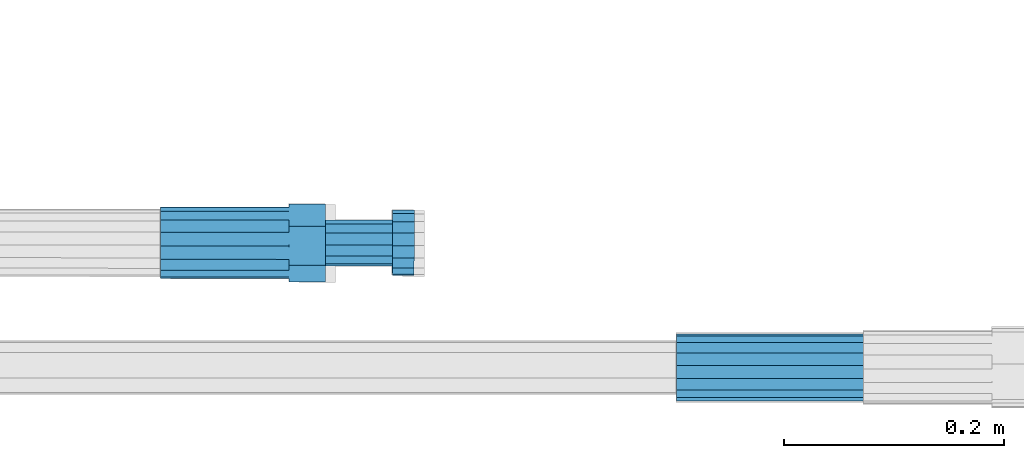
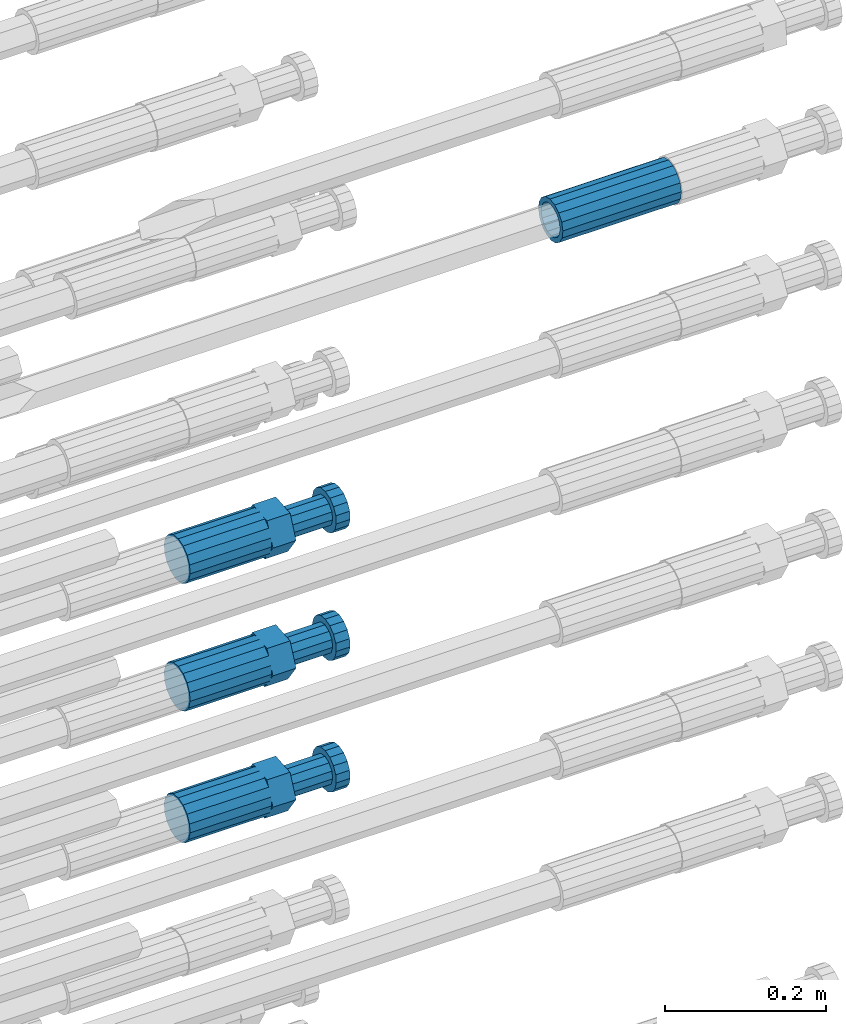
# One storey, part 102 of 177: 4 beams.
"""IFC2X3 building model written with IfcOpenShell, lengths in millimetres."""

import ifcopenshell
import ifcopenshell.guid

model = None  # the IFC model being written
_history = None  # IfcOwnerHistory: only IFC2X3 demands one
_inside = {}  # id of a spatial element -> (the spatial element, [elements in it])
_under = {}  # id of a project, library or spatial element -> (it, [spatial elements below it])
_declared = {}  # id of a project -> (the project, [libraries it declares])
_typed = {}  # id of a type object -> (the type object, [elements of that type])
_made_of = {}  # id of a material, layer set ... -> (it, [elements and type objects made of it])


def new_model(schema):
    """Start an empty IFC model of exactly this schema.

    Asked for "IFC4X3", IfcOpenShell would pick the latest addendum, in which some entities
    have other attributes; the version numbers below select the first issue.
    IFC2X3 requires an IfcOwnerHistory on every rooted entity: one is made here for all.
    """
    global model, _history
    if schema == "IFC4X3":
        model = ifcopenshell.file(schema_version=(4, 3, 0, 0))
    else:
        model = ifcopenshell.file(schema=schema)
    _inside.clear()
    _under.clear()
    _declared.clear()
    _typed.clear()
    _made_of.clear()
    _history = None
    if model.schema == "IFC2X3":
        org = make("IfcOrganization", Name="unknown")
        user = make(
            "IfcPersonAndOrganization",
            ThePerson=make("IfcPerson", FamilyName="unknown"),
            TheOrganization=org,
        )
        app = make(
            "IfcApplication",
            ApplicationDeveloper=org,
            Version="unknown",
            ApplicationFullName="unknown",
            ApplicationIdentifier="unknown",
        )
        _history = make(
            "IfcOwnerHistory",
            OwningUser=user,
            OwningApplication=app,
            ChangeAction="ADDED",
            CreationDate=0,
        )
    return model


def make(cls, **values):
    """One entity of the class cls with the attributes given. An attribute that is None is left unset."""
    return model.create_entity(
        cls, **{name: value for name, value in values.items() if value is not None}
    )


def rooted(cls, **values):
    """An entity with a GlobalId (a new one), such as an element, a storey or a relation."""
    return make(cls, GlobalId=ifcopenshell.guid.new(), OwnerHistory=_history, **values)


def si_unit(unit_type, name, prefix=None):
    """IfcSIUnit, for example si_unit("LENGTHUNIT", "METRE", prefix="MILLI")."""
    return make("IfcSIUnit", UnitType=unit_type, Prefix=prefix, Name=name)


def assignment(units):
    """IfcUnitAssignment: the units of a project."""
    return None if units is None else make("IfcUnitAssignment", Units=units)


def point(xyz):
    """IfcCartesianPoint."""
    return None if xyz is None else make("IfcCartesianPoint", Coordinates=xyz)


def direction(xyz):
    """IfcDirection."""
    return None if xyz is None else make("IfcDirection", DirectionRatios=xyz)


def frame(location, z_axis=None, x_axis=None):
    """IfcAxis2Placement3D, a coordinate frame: its origin and axes. An axis left out is left unset."""
    return make(
        "IfcAxis2Placement3D",
        Location=point(location),
        Axis=direction(z_axis),
        RefDirection=direction(x_axis),
    )


def origin_with_axes():
    """The frame at (0, 0, 0) with the z axis (0, 0, 1) and the x axis (1, 0, 0) written out."""
    return frame((0.0, 0.0, 0.0), z_axis=(0.0, 0.0, 1.0), x_axis=(1.0, 0.0, 0.0))


def place(relative_to, where):
    """IfcLocalPlacement: puts the frame where relative to a parent placement (None: the world)."""
    return make(
        "IfcLocalPlacement", PlacementRelTo=relative_to, RelativePlacement=where
    )


def context(
    kind, dimensions, precision=None, world=None, true_north=None, identifier=None
):
    """IfcGeometricRepresentationContext, for example the 3D "Model" context."""
    return make(
        "IfcGeometricRepresentationContext",
        ContextIdentifier=identifier,
        ContextType=kind,
        CoordinateSpaceDimension=dimensions,
        Precision=precision,
        WorldCoordinateSystem=world,
        TrueNorth=true_north,
    )


def subcontext(parent, identifier, kind, view, scale=None):
    """IfcGeometricRepresentationSubContext, for example "Body" below "Model"."""
    return make(
        "IfcGeometricRepresentationSubContext",
        ContextIdentifier=identifier,
        ContextType=kind,
        ParentContext=parent,
        TargetScale=scale,
        TargetView=view,
    )


def project(units=None, contexts=None):
    """IfcProject with its units and contexts."""
    return rooted(
        "IfcProject",
        Name="project",
        RepresentationContexts=contexts,
        UnitsInContext=assignment(units),
    )


def spatial(cls, under=None, at=None, **own):
    """A site, building, storey or space (cls), placed at a placement, below another one or the project."""
    s = rooted(cls, ObjectPlacement=at, **own)
    if under is not None:
        _under.setdefault(under.id(), (under, []))[1].append(s)
    return s


def faces_of(points, faces, orient=None, outer=None):
    """IfcFace entities. A face is a list of loops; a loop is a list of indices into points, from 0.

    orient and outer hold one flag for each loop. By default every Orientation is true, the
    first loop of a face is its IfcFaceOuterBound and the others are IfcFaceBound.
    """
    made = []
    for i, loops in enumerate(faces):
        bounds = []
        for j, loop in enumerate(loops):
            is_outer = j == 0 if outer is None else outer[i][j]
            bounds.append(
                make(
                    "IfcFaceOuterBound" if is_outer else "IfcFaceBound",
                    Bound=make("IfcPolyLoop", Polygon=[points[k] for k in loop]),
                    Orientation=True if orient is None else orient[i][j],
                )
            )
        made.append(make("IfcFace", Bounds=bounds))
    return made


def faceted_brep(points, faces, orient=None, outer=None, voids=None):
    """IfcFacetedBrep: a solid bounded by flat faces; with voids (closed shells), ...WithVoids."""
    shared = [point(p) for p in points]
    hull = make("IfcClosedShell", CfsFaces=faces_of(shared, faces, orient, outer))
    if voids is None:
        return make("IfcFacetedBrep", Outer=hull)
    return make(
        "IfcFacetedBrepWithVoids",
        Outer=hull,
        Voids=[
            make(cls, CfsFaces=faces_of(shared, fs, o, b)) for cls, fs, o, b in voids
        ],
    )


def shape(context_of_items, identifier, shape_type, items):
    """IfcShapeRepresentation: the items that make up one representation, for example the "Body"."""
    return make(
        "IfcShapeRepresentation",
        ContextOfItems=context_of_items,
        RepresentationIdentifier=identifier,
        RepresentationType=shape_type,
        Items=items,
    )


def material(Name=None, Category=None):
    """IfcMaterial."""
    return make("IfcMaterial", Name=Name, Category=Category)


def made_of(thing, what):
    """Note that an element or type object is made of a material, layer set ...; save() writes the relation."""
    if what is not None:
        _made_of.setdefault(what.id(), (what, []))[1].append(thing)
    return thing


def type_object(cls, material=None, **own):
    """A type object (cls), such as IfcWallType, which elements share."""
    return made_of(rooted(cls, **own), material)


def element(
    cls,
    number,
    at=None,
    inside=None,
    cuts=None,
    type_object=None,
    material=None,
    context=None,
    identifier="Body",
    shape_type=None,
    held_by="IfcProductDefinitionShape",
    body=None,
    shapes=None,
    **own,
):
    """One element of the class cls, such as IfcWall. Its Tag is "e" and its number.

    at: its placement. inside: the storey or other place that contains it. cuts: it is an
    opening in that element (IfcRelVoidsElement). A single representation is given by context,
    identifier, shape_type and body (its items); several are given by shapes. held_by: the class
    of the entity that holds the representations. save() writes the other relations.
    """
    e = rooted(cls, Tag="e%d" % number, ObjectPlacement=at, **own)
    if body is not None:
        shapes = [shape(context, identifier, shape_type, body)]
    if shapes is not None:
        e.Representation = make(held_by, Representations=shapes)
    if inside is not None:
        _inside.setdefault(inside.id(), (inside, []))[1].append(e)
    if cuts is not None:
        rooted(
            "IfcRelVoidsElement", RelatingBuildingElement=cuts, RelatedOpeningElement=e
        )
    if type_object is not None:
        _typed.setdefault(type_object.id(), (type_object, []))[1].append(e)
    return made_of(e, material)


def aggregate(whole, parts):
    """IfcRelAggregates: a whole, such as a stair, and the parts it consists of."""
    return rooted("IfcRelAggregates", RelatingObject=whole, RelatedObjects=parts)


def save(model, path):
    """Write the relations noted so far, then the file.

    IfcRelAggregates (storeys below a building ...), IfcRelContainedInSpatialStructure (elements
    in a storey), IfcRelDefinesByType, IfcRelAssociatesMaterial and IfcRelDeclares: one each for
    every whole, place, type object, material and project.
    """
    for whole, parts in _under.values():
        aggregate(whole, parts)
    for where, things in _inside.values():
        rooted(
            "IfcRelContainedInSpatialStructure",
            RelatedElements=things,
            RelatingStructure=where,
        )
    for kind, things in _typed.values():
        rooted("IfcRelDefinesByType", RelatedObjects=things, RelatingType=kind)
    for what, things in _made_of.values():
        rooted("IfcRelAssociatesMaterial", RelatedObjects=things, RelatingMaterial=what)
    for by, libraries in _declared.values():
        rooted("IfcRelDeclares", RelatingContext=by, RelatedDefinitions=libraries)
    model.write(path)


model = new_model("IFC2X3")

# Units and contexts
model_context_1 = context("Model", 3, precision=1e-05, world=origin_with_axes())
model_context_2 = context("Model", 3, precision=1e-05, world=origin_with_axes())
body_context = subcontext(model_context_2, "Body", "Model", "MODEL_VIEW")
ifc_project = project(units=[si_unit("LENGTHUNIT", "METRE", prefix="MILLI"), si_unit("AREAUNIT", "SQUARE_METRE"), si_unit("VOLUMEUNIT", "CUBIC_METRE"), si_unit("MASSUNIT", "GRAM", prefix="KILO"), si_unit("TIMEUNIT", "SECOND"), si_unit("PLANEANGLEUNIT", "RADIAN"), si_unit("SOLIDANGLEUNIT", "STERADIAN"), si_unit("THERMODYNAMICTEMPERATUREUNIT", "DEGREE_CELSIUS"), si_unit("LUMINOUSINTENSITYUNIT", "LUMEN")], contexts=[model_context_1])

# Site, building, storey
site_placement = place(None, origin_with_axes())
site = spatial("IfcSite", under=ifc_project, at=site_placement, CompositionType="ELEMENT")
building_placement = place(site_placement, origin_with_axes())
building = spatial("IfcBuilding", under=site, at=building_placement, Name="Undefined", CompositionType="ELEMENT")
storey_placement = place(building_placement, origin_with_axes())
storey = spatial("IfcBuildingStorey", under=building, at=storey_placement, Name="Undefined", CompositionType="ELEMENT", Elevation=0.0)

# Beams
ifc_material = material(Name="STEEL/S275")
beam_type_1 = type_object("IfcBeamType", PredefinedType="NOTDEFINED")
beam_1_placement = place(storey_placement, frame((2039349.5158443, 6205099.55100679, 20771.9949067075), z_axis=(0.0, -0.0523359559876842, -0.998629534767952), x_axis=(1.0, 0.0, 0.0)))
element("IfcBeam", 1, at=beam_1_placement, inside=storey, type_object=beam_type_1, material=ifc_material, Name="AG40N", context=body_context, shape_type="Brep", body=[
    faceted_brep([(0.0, -23.5000000001164, -9.31322574615479e-10), (0.0, -21.7111690140155, 8.99306066054851), (170.0, -21.7111690140155, 8.99306066054851), (170.0, -23.5, 0.0), (0.0, -16.6170093578839, 16.6170093575493), (170.0, -16.6170093578839, 16.6170093575493), (0.0, -8.99306066057943, 21.7111690137535), (170.0, -8.99306066057943, 21.7111690137535), (0.0, 1.16415321826935e-10, 23.5), (170.0, 0.0, 23.5), (0.0, 8.99306066057943, 21.7111690137535), (170.0, 8.99306066057943, 21.7111690137535), (0.0, 16.6170093578839, 16.6170093575493), (170.0, 16.6170093578839, 16.6170093575493), (0.0, 21.7111690140155, 8.99306066054851), (170.0, 21.7111690140155, 8.99306066054851), (0.0, 23.5000000001164, -9.31322574615479e-10), (170.0, 23.5, 0.0), (0.0, 21.7111690140155, -8.99306066054851), (170.0, 21.7111690140155, -8.99306066054851), (0.0, 16.6170093578839, -16.6170093575493), (170.0, 16.6170093578839, -16.6170093575493), (0.0, 8.99306066057943, -21.7111690137535), (170.0, 8.99306066057943, -21.7111690137535), (0.0, 1.16415321826935e-10, -23.5000000009313), (170.0, 0.0, -23.5), (0.0, -8.99306066057943, -21.7111690137535), (170.0, -8.99306066057943, -21.7111690137535), (0.0, -16.6170093578839, -16.6170093575493), (170.0, -16.6170093578839, -16.6170093575493), (0.0, -21.7111690140155, -8.99306066054851), (170.0, -21.7111690140155, -8.99306066054851), (0.0, -30.5, 0.0), (0.0, -28.1783257415937, -11.6718446873128), (170.0, -28.1783257415937, -11.6718446873128), (170.0, -30.5, 0.0), (0.0, -21.5667568261888, -21.5667568258941), (170.0, -21.5667568261888, -21.5667568258941), (0.0, -11.6718446871346, -28.1783257415518), (170.0, -11.6718446871346, -28.1783257415518), (0.0, 0.0, -30.5), (170.0, 0.0, -30.5), (0.0, 11.6718446871346, -28.1783257415518), (170.0, 11.6718446871346, -28.1783257415518), (0.0, 21.5667568261888, -21.5667568258941), (170.0, 21.5667568261888, -21.5667568258941), (0.0, 28.1783257415937, -11.6718446873128), (170.0, 28.1783257415937, -11.6718446873128), (0.0, 30.5, 0.0), (170.0, 30.5, 0.0), (0.0, 28.1783257415937, 11.6718446873128), (170.0, 28.1783257415937, 11.6718446873128), (0.0, 21.5667568261888, 21.5667568258941), (170.0, 21.5667568261888, 21.5667568258941), (0.0, 11.6718446871346, 28.1783257415518), (170.0, 11.6718446871346, 28.1783257415518), (0.0, 0.0, 30.5), (170.0, 0.0, 30.5), (0.0, -11.6718446871346, 28.1783257415518), (170.0, -11.6718446871346, 28.1783257415518), (0.0, -21.5667568261888, 21.5667568258941), (170.0, -21.5667568261888, 21.5667568258941), (0.0, -28.1783257415937, 11.6718446873128), (170.0, -28.1783257415937, 11.6718446873128)], [[[0, 1, 2, 3]], [[1, 4, 5, 2]], [[4, 6, 7, 5]], [[6, 8, 9, 7]], [[8, 10, 11, 9]], [[10, 12, 13, 11]], [[12, 14, 15, 13]], [[14, 16, 17, 15]], [[16, 18, 19, 17]], [[18, 20, 21, 19]], [[20, 22, 23, 21]], [[22, 24, 25, 23]], [[24, 26, 27, 25]], [[26, 28, 29, 27]], [[28, 30, 31, 29]], [[30, 0, 3, 31]], [[32, 33, 34, 35]], [[33, 36, 37, 34]], [[36, 38, 39, 37]], [[38, 40, 41, 39]], [[40, 42, 43, 41]], [[42, 44, 45, 43]], [[44, 46, 47, 45]], [[46, 48, 49, 47]], [[48, 50, 51, 49]], [[50, 52, 53, 51]], [[52, 54, 55, 53]], [[54, 56, 57, 55]], [[56, 58, 59, 57]], [[58, 60, 61, 59]], [[60, 62, 63, 61]], [[62, 32, 35, 63]], [[37, 39, 41, 43, 45, 47, 49, 51, 53, 55, 57, 59, 61, 63, 35, 34], [5, 7, 9, 11, 13, 15, 17, 19, 21, 23, 25, 27, 29, 31, 3, 2]], [[62, 60, 58, 56, 54, 52, 50, 48, 46, 44, 42, 40, 38, 36, 33, 32], [30, 28, 26, 24, 22, 20, 18, 16, 14, 12, 10, 8, 6, 4, 1, 0]]]),
])
beam_type_2 = type_object("IfcBeamType", Name="ROD65", PredefinedType="NOTDEFINED")
beam_2_placement = place(storey_placement, frame((2038879.51584447, 6205213.0123221, 20353.9143277543), z_axis=(0.0, 0.0941083139572259, -0.995561964542704), x_axis=(1.0, 0.0, 0.0)))
element("IfcBeam", 2, at=beam_2_placement, inside=storey, type_object=beam_type_2, material=ifc_material, Name="AGB40", ObjectType="ROD65", context=body_context, shape_type="Brep", body=[
    faceted_brep([(117.0, 8.17543110251427, 30.873805644922), (117.0, 17.8250000001863, 30.873805644922), (117.0, 22.0056958701462, 23.6326279877685), (117.0, 12.4372115517035, 30.0260848065373), (117.0, -17.8250000001863, 30.873805644922), (150.200000000186, -17.8250000001863, 30.873805644922), (150.200000000186, 17.8250000001863, 30.873805644922), (117.0, -8.17543110251427, 30.873805644922), (117.0, -12.4372115517035, 30.0260848065373), (117.0, -22.0056958701462, 23.6326279877685), (117.0, -35.6500000003725, 0.0), (150.200000000186, -35.6500000003725, 0.0), (117.0, -30.8443150008097, 8.32369058486074), (117.0, -32.5, 0.0), (117.0, -30.8443150008097, -8.32369058462791), (117.0, -17.8250000001863, -30.873805644922), (150.200000000186, -17.8250000001863, -30.873805644922), (117.0, -22.0056958701462, -23.6326279877685), (117.0, -12.4372115517035, -30.0260848065373), (117.0, -8.17543110251427, -30.873805644922), (117.0, 17.8250000001863, -30.873805644922), (150.200000000186, 17.8250000001863, -30.873805644922), (117.0, 8.17543110251427, -30.873805644922), (117.0, 22.0056958701462, -23.6326279877685), (117.0, 12.4372115517035, -30.0260848065373), (117.0, 35.6500000003725, 0.0), (150.200000000186, 35.6500000003725, 0.0), (117.0, 30.8443150008097, -8.32369058486074), (117.0, 30.8443150008097, 8.32369058462791), (117.0, 32.5, 0.0), (0.0, -22.9809703892097, 22.9809703885621), (0.0, -30.0260848058388, 12.4372115518636), (117.0, -30.0260848067701, 12.4372115519363), (117.0, -22.9809703882784, 22.9809703885112), (-2.3283064365387e-10, 22.9809703892097, -22.9809703885639), (-4.65661287307739e-10, 30.0260848077014, -12.4372115518672), (117.0, 30.0260848067701, -12.4372115519363), (117.0, 22.9809703882784, -22.9809703885112), (-2.3283064365387e-10, -30.0260848067701, -12.4372115518672), (-2.3283064365387e-10, -22.9809703892097, -22.9809703885621), (117.0, -22.9809703882784, -22.9809703885112), (117.0, -30.0260848067701, -12.4372115519363), (-2.3283064365387e-10, -12.4372115507722, 30.0260848066137), (-2.3283064365387e-10, 9.31322574615479e-10, 32.4999999999982), (-2.3283064365387e-10, 12.4372115526348, 30.0260848066137), (0.0, 22.9809703892097, 22.9809703885621), (-2.3283064365387e-10, 30.0260848077014, 12.4372115518636), (-2.3283064365387e-10, 32.5, 0.0), (-2.3283064365387e-10, 12.4372115526348, -30.0260848066173), (-2.3283064365387e-10, 9.31322574615479e-10, -32.5), (-2.3283064365387e-10, -12.4372115517035, -30.0260848066173), (-4.65661287307739e-10, -32.4999999990687, -1.81898940354586e-12), (117.0, 22.9809703882784, 22.9809703885112), (117.0, 30.0260848067701, 12.4372115519363), (117.0, 0.0, -32.5), (117.0, 0.0, 32.5), (150.200000000186, 10.5, -18.1865334794857), (150.200000000186, 0.0, -21.0), (150.200000000186, -10.5, -18.1865334794857), (150.200000000186, -18.18653347902, -10.5), (150.200000000186, -21.0, 0.0), (150.200000000186, -18.18653347902, 10.5), (150.200000000186, -10.5, 18.1865334794857), (150.200000000186, 0.0, 21.0), (150.200000000186, 10.5, 18.1865334794857), (150.200000000186, 18.18653347902, 10.5), (150.200000000186, 21.0, 0.0), (150.200000000186, 18.18653347902, -10.5), (210.980000000447, -18.18653347902, 10.5), (210.980000000447, -21.0, 0.0), (210.980000000447, -10.5, 18.1865334794857), (210.980000000447, 0.0, 21.0), (210.980000000447, 10.5, 18.1865334794857), (210.980000000447, 18.18653347902, 10.5), (210.980000000447, 21.0, 0.0), (210.980000000447, 18.18653347902, -10.5), (210.980000000447, 10.5, -18.1865334794857), (210.980000000447, 0.0, -21.0), (210.980000000447, -10.5, -18.1865334794857), (210.980000000447, -18.18653347902, -10.5), (211.001368442696, -27.7269937992096, -11.491116326768), (211.003082550167, -21.2238094303757, -21.223815418547), (231.002518367059, -21.2131944671273, -21.2132004550658), (231.000804259587, -27.7163788359612, -11.4805013632867), (211.001368440451, -11.4911085031927, -27.7269970395137), (231.000804257343, -11.4804935399443, -27.7163820760325), (210.996487071217, -0.0106065049767494, -30.0106107392348), (230.995922888109, 8.45827162265778e-06, -29.9999957757536), (210.989181586672, 11.46989420522, -27.7269970329944), (230.988617403564, 11.4805091684684, -27.7163820695132), (210.980564180623, 21.2025914648548, -21.2238154064398), (230.979999997515, 21.2132064281031, -21.2132004429586), (210.971946775022, 27.7057703435421, -11.4911163107026), (230.971382591913, 27.7163853067905, -11.4805013472214), (210.96464129175, 29.9893808094785, -0.0106149562634528), (230.964077108642, 29.9999957727268, 7.21774995326996e-09), (210.959759924415, 27.7057638689876, 11.4698863970116), (230.959195741307, 27.7163788322359, 11.4805013604928), (210.958045816944, 21.2025795001537, 21.2025854887906), (230.957481633835, 21.213194463402, 21.2132004522718), (210.95975992666, 11.4698785729706, 27.7057671097573), (230.959195743551, 11.480493536219, 27.7163820732385), (210.964641295894, -0.010623425245285, 29.9893808094785), (230.964077112785, -8.46199691295624e-06, 29.9999957729597), (210.971946780439, -11.4911241354421, 27.705767103238), (230.97138259733, -11.4805091721937, 27.7163820667192), (210.980564186488, -21.2238213950768, 21.2025854766835), (230.980000003379, -21.2132064318284, 21.2132004401647), (210.989181592089, -27.7270002737641, 11.4698863809463), (230.988617408981, -27.7163853105158, 11.4805013444275), (210.996487075361, -30.0106107397005, -0.0106149734929204), (230.995922892253, -29.9999957764521, -1.00117176771164e-08)], [[[0, 1, 2, 3]], [[4, 5, 6, 1, 0, 7]], [[4, 7, 8, 9]], [[10, 11, 5, 4, 9, 12]], [[10, 12, 13, 14]], [[15, 16, 11, 10, 14, 17]], [[15, 17, 18, 19]], [[20, 21, 16, 15, 19, 22]], [[23, 20, 22, 24]], [[25, 26, 21, 20, 23, 27]], [[28, 25, 27, 29]], [[30, 31, 32, 33]], [[34, 35, 36, 37]], [[38, 39, 40, 41]], [[31, 30, 42, 43, 44, 45, 46, 47, 35, 34, 48, 49, 50, 39, 38, 51]], [[46, 45, 52, 53]], [[29, 47, 46, 53, 28]], [[27, 36, 35, 47, 29]], [[23, 37, 36, 27]], [[24, 48, 34, 37, 23]], [[22, 54, 49, 48, 24]], [[19, 54, 22]], [[18, 50, 49, 54, 19]], [[17, 40, 39, 50, 18]], [[14, 41, 40, 17]], [[13, 51, 38, 41, 14]], [[12, 32, 31, 51, 13]], [[9, 33, 32, 12]], [[8, 42, 30, 33, 9]], [[7, 55, 43, 42, 8]], [[0, 55, 7]], [[3, 44, 43, 55, 0]], [[2, 52, 45, 44, 3]], [[28, 53, 52, 2]], [[1, 6, 26, 25, 28, 2]], [[5, 11, 16, 21, 26, 6], [56, 57, 58, 59, 60, 61, 62, 63, 64, 65, 66, 67]], [[68, 61, 60, 69]], [[70, 62, 61, 68]], [[71, 63, 62, 70]], [[72, 64, 63, 71]], [[73, 65, 64, 72]], [[74, 66, 65, 73]], [[75, 67, 66, 74]], [[76, 56, 67, 75]], [[77, 57, 56, 76]], [[78, 58, 57, 77]], [[79, 59, 58, 78]], [[69, 60, 59, 79]], [[80, 81, 82, 83]], [[81, 84, 85, 82]], [[84, 86, 87, 85]], [[86, 88, 89, 87]], [[88, 90, 91, 89]], [[90, 92, 93, 91]], [[92, 94, 95, 93]], [[94, 96, 97, 95]], [[96, 98, 99, 97]], [[98, 100, 101, 99]], [[100, 102, 103, 101]], [[102, 104, 105, 103]], [[104, 106, 107, 105]], [[106, 108, 109, 107]], [[108, 110, 111, 109]], [[82, 85, 87, 89, 91, 93, 95, 97, 99, 101, 103, 105, 107, 109, 111, 83]], [[110, 80, 83, 111]], [[108, 106, 104, 102, 100, 98, 96, 94, 92, 90, 88, 86, 84, 81, 80, 110], [75, 74, 73, 72, 71, 70, 68, 69, 79, 78, 77, 76]]]),
])
beam_3_placement = place(storey_placement, frame((2038879.51584447, 6205213.02826476, 20160.380139302), z_axis=(0.0, 0.090632580959236, -0.995884398546672), x_axis=(1.0, 0.0, 0.0)))
element("IfcBeam", 3, at=beam_3_placement, inside=storey, type_object=beam_type_2, material=ifc_material, Name="AGB40", ObjectType="ROD65", context=body_context, shape_type="Brep", body=[
    faceted_brep([(117.0, 8.17543110251427, 30.873805644922), (117.0, 17.8250000001863, 30.873805644922), (117.0, 22.0056958701462, 23.6326279877685), (117.0, 12.4372115517035, 30.0260848065373), (117.0, -17.8250000001863, 30.873805644922), (150.200000000186, -17.8250000001863, 30.873805644922), (150.200000000186, 17.8250000001863, 30.873805644922), (117.0, -8.17543110251427, 30.873805644922), (117.0, -12.4372115517035, 30.0260848065373), (117.0, -22.0056958701462, 23.6326279877685), (117.0, -35.6500000003725, 0.0), (150.200000000186, -35.6500000003725, 0.0), (117.0, -30.8443150008097, 8.32369058486074), (117.0, -32.5, 0.0), (117.0, -30.8443150008097, -8.32369058462791), (117.0, -17.8250000001863, -30.873805644922), (150.200000000186, -17.8250000001863, -30.873805644922), (117.0, -22.0056958701462, -23.6326279877685), (117.0, -12.4372115517035, -30.0260848065373), (117.0, -8.17543110251427, -30.873805644922), (117.0, 17.8250000001863, -30.873805644922), (150.200000000186, 17.8250000001863, -30.873805644922), (117.0, 8.17543110251427, -30.873805644922), (117.0, 22.0056958701462, -23.6326279877685), (117.0, 12.4372115517035, -30.0260848065373), (117.0, 35.6500000003725, 0.0), (150.200000000186, 35.6500000003725, 0.0), (117.0, 30.8443150008097, -8.32369058486074), (117.0, 30.8443150008097, 8.32369058462791), (117.0, 32.5, 0.0), (0.0, -22.9809703892097, 22.9809703885621), (0.0, -30.0260848058388, 12.4372115518636), (117.0, -30.0260848067701, 12.4372115519363), (117.0, -22.9809703882784, 22.9809703885112), (-2.3283064365387e-10, 22.9809703892097, -22.9809703885639), (-4.65661287307739e-10, 30.0260848077014, -12.4372115518672), (117.0, 30.0260848067701, -12.4372115519363), (117.0, 22.9809703882784, -22.9809703885112), (-2.3283064365387e-10, -30.0260848067701, -12.4372115518672), (-2.3283064365387e-10, -22.9809703892097, -22.9809703885621), (117.0, -22.9809703882784, -22.9809703885112), (117.0, -30.0260848067701, -12.4372115519363), (-2.3283064365387e-10, -12.4372115507722, 30.0260848066137), (-2.3283064365387e-10, 9.31322574615479e-10, 32.4999999999982), (-2.3283064365387e-10, 12.4372115526348, 30.0260848066137), (0.0, 22.9809703892097, 22.9809703885621), (-2.3283064365387e-10, 30.0260848077014, 12.4372115518636), (-2.3283064365387e-10, 32.5, 0.0), (-2.3283064365387e-10, 12.4372115526348, -30.0260848066173), (-2.3283064365387e-10, 9.31322574615479e-10, -32.5), (-2.3283064365387e-10, -12.4372115517035, -30.0260848066173), (-4.65661287307739e-10, -32.4999999990687, -1.81898940354586e-12), (117.0, 22.9809703882784, 22.9809703885112), (117.0, 30.0260848067701, 12.4372115519363), (117.0, 0.0, -32.5), (117.0, 0.0, 32.5), (150.200000000186, 10.5, -18.1865334794857), (150.200000000186, 0.0, -21.0), (150.200000000186, -10.5, -18.1865334794857), (150.200000000186, -18.18653347902, -10.5), (150.200000000186, -21.0, 0.0), (150.200000000186, -18.18653347902, 10.5), (150.200000000186, -10.5, 18.1865334794857), (150.200000000186, 0.0, 21.0), (150.200000000186, 10.5, 18.1865334794857), (150.200000000186, 18.18653347902, 10.5), (150.200000000186, 21.0, 0.0), (150.200000000186, 18.18653347902, -10.5), (210.980000000447, -18.18653347902, 10.5), (210.980000000447, -21.0, 0.0), (210.980000000447, -10.5, 18.1865334794857), (210.980000000447, 0.0, 21.0), (210.980000000447, 10.5, 18.1865334794857), (210.980000000447, 18.18653347902, 10.5), (210.980000000447, 21.0, 0.0), (210.980000000447, 18.18653347902, -10.5), (210.980000000447, 10.5, -18.1865334794857), (210.980000000447, 0.0, -21.0), (210.980000000447, -10.5, -18.1865334794857), (210.980000000447, -18.18653347902, -10.5), (211.001368442696, -27.7269937992096, -11.491116326768), (211.003082550167, -21.2238094303757, -21.223815418547), (231.002518367059, -21.2131944671273, -21.2132004550658), (231.000804259587, -27.7163788359612, -11.4805013632867), (211.001368440451, -11.4911085031927, -27.7269970395137), (231.000804257343, -11.4804935399443, -27.7163820760325), (210.996487071217, -0.0106065049767494, -30.0106107392348), (230.995922888109, 8.45827162265778e-06, -29.9999957757536), (210.989181586672, 11.46989420522, -27.7269970329944), (230.988617403564, 11.4805091684684, -27.7163820695132), (210.980564180623, 21.2025914648548, -21.2238154064398), (230.979999997515, 21.2132064281031, -21.2132004429586), (210.971946775022, 27.7057703435421, -11.4911163107026), (230.971382591913, 27.7163853067905, -11.4805013472214), (210.96464129175, 29.9893808094785, -0.0106149562634528), (230.964077108642, 29.9999957727268, 7.21774995326996e-09), (210.959759924415, 27.7057638689876, 11.4698863970116), (230.959195741307, 27.7163788322359, 11.4805013604928), (210.958045816944, 21.2025795001537, 21.2025854887906), (230.957481633835, 21.213194463402, 21.2132004522718), (210.95975992666, 11.4698785729706, 27.7057671097573), (230.959195743551, 11.480493536219, 27.7163820732385), (210.964641295894, -0.010623425245285, 29.9893808094785), (230.964077112785, -8.46199691295624e-06, 29.9999957729597), (210.971946780439, -11.4911241354421, 27.705767103238), (230.97138259733, -11.4805091721937, 27.7163820667192), (210.980564186488, -21.2238213950768, 21.2025854766835), (230.980000003379, -21.2132064318284, 21.2132004401647), (210.989181592089, -27.7270002737641, 11.4698863809463), (230.988617408981, -27.7163853105158, 11.4805013444275), (210.996487075361, -30.0106107397005, -0.0106149734929204), (230.995922892253, -29.9999957764521, -1.00117176771164e-08)], [[[0, 1, 2, 3]], [[4, 5, 6, 1, 0, 7]], [[4, 7, 8, 9]], [[10, 11, 5, 4, 9, 12]], [[10, 12, 13, 14]], [[15, 16, 11, 10, 14, 17]], [[15, 17, 18, 19]], [[20, 21, 16, 15, 19, 22]], [[23, 20, 22, 24]], [[25, 26, 21, 20, 23, 27]], [[28, 25, 27, 29]], [[30, 31, 32, 33]], [[34, 35, 36, 37]], [[38, 39, 40, 41]], [[31, 30, 42, 43, 44, 45, 46, 47, 35, 34, 48, 49, 50, 39, 38, 51]], [[46, 45, 52, 53]], [[29, 47, 46, 53, 28]], [[27, 36, 35, 47, 29]], [[23, 37, 36, 27]], [[24, 48, 34, 37, 23]], [[22, 54, 49, 48, 24]], [[19, 54, 22]], [[18, 50, 49, 54, 19]], [[17, 40, 39, 50, 18]], [[14, 41, 40, 17]], [[13, 51, 38, 41, 14]], [[12, 32, 31, 51, 13]], [[9, 33, 32, 12]], [[8, 42, 30, 33, 9]], [[7, 55, 43, 42, 8]], [[0, 55, 7]], [[3, 44, 43, 55, 0]], [[2, 52, 45, 44, 3]], [[28, 53, 52, 2]], [[1, 6, 26, 25, 28, 2]], [[5, 11, 16, 21, 26, 6], [56, 57, 58, 59, 60, 61, 62, 63, 64, 65, 66, 67]], [[68, 61, 60, 69]], [[70, 62, 61, 68]], [[71, 63, 62, 70]], [[72, 64, 63, 71]], [[73, 65, 64, 72]], [[74, 66, 65, 73]], [[75, 67, 66, 74]], [[76, 56, 67, 75]], [[77, 57, 56, 76]], [[78, 58, 57, 77]], [[79, 59, 58, 78]], [[69, 60, 59, 79]], [[80, 81, 82, 83]], [[81, 84, 85, 82]], [[84, 86, 87, 85]], [[86, 88, 89, 87]], [[88, 90, 91, 89]], [[90, 92, 93, 91]], [[92, 94, 95, 93]], [[94, 96, 97, 95]], [[96, 98, 99, 97]], [[98, 100, 101, 99]], [[100, 102, 103, 101]], [[102, 104, 105, 103]], [[104, 106, 107, 105]], [[106, 108, 109, 107]], [[108, 110, 111, 109]], [[82, 85, 87, 89, 91, 93, 95, 97, 99, 101, 103, 105, 107, 109, 111, 83]], [[110, 80, 83, 111]], [[108, 106, 104, 102, 100, 98, 96, 94, 92, 90, 88, 86, 84, 81, 80, 110], [75, 74, 73, 72, 71, 70, 68, 69, 79, 78, 77, 76]]]),
])
beam_4_placement = place(storey_placement, frame((2038879.5159012, 6205213.07017149, 19961.0192502578), z_axis=(2.42054155096406e-05, 0.0871557380184512, -0.996194698211427), x_axis=(0.999999961434133, -0.000277726001599007, 0.0)))
element("IfcBeam", 4, at=beam_4_placement, inside=storey, type_object=beam_type_2, material=ifc_material, Name="AGB40", ObjectType="ROD65", context=body_context, shape_type="Brep", body=[
    faceted_brep([(117.0, 8.17543110251427, 30.873805644922), (117.0, 17.8250000001863, 30.873805644922), (117.0, 22.0056958701462, 23.6326279877685), (117.0, 12.4372115517035, 30.0260848065373), (117.0, -17.8250000001863, 30.873805644922), (150.200000000186, -17.8250000001863, 30.873805644922), (150.200000000186, 17.8250000001863, 30.873805644922), (117.0, -8.17543110251427, 30.873805644922), (117.0, -12.4372115517035, 30.0260848065373), (117.0, -22.0056958701462, 23.6326279877685), (117.0, -35.6500000003725, 0.0), (150.200000000186, -35.6500000003725, 0.0), (117.0, -30.8443150008097, 8.32369058486074), (117.0, -32.5, 0.0), (117.0, -30.8443150008097, -8.32369058462791), (117.0, -17.8250000001863, -30.873805644922), (150.200000000186, -17.8250000001863, -30.873805644922), (117.0, -22.0056958701462, -23.6326279877685), (117.0, -12.4372115517035, -30.0260848065373), (117.0, -8.17543110251427, -30.873805644922), (117.0, 17.8250000001863, -30.873805644922), (150.200000000186, 17.8250000001863, -30.873805644922), (117.0, 8.17543110251427, -30.873805644922), (117.0, 22.0056958701462, -23.6326279877685), (117.0, 12.4372115517035, -30.0260848065373), (117.0, 35.6500000003725, 0.0), (150.200000000186, 35.6500000003725, 0.0), (117.0, 30.8443150008097, -8.32369058486074), (117.0, 30.8443150008097, 8.32369058462791), (117.0, 32.5, 0.0), (0.0, -22.9809703892097, 22.9809703885621), (0.0, -30.0260848058388, 12.4372115518636), (117.0, -30.0260848067701, 12.4372115519363), (117.0, -22.9809703882784, 22.9809703885112), (-2.3283064365387e-10, 22.9809703892097, -22.9809703885639), (-4.65661287307739e-10, 30.0260848077014, -12.4372115518672), (117.0, 30.0260848067701, -12.4372115519363), (117.0, 22.9809703882784, -22.9809703885112), (-2.3283064365387e-10, -30.0260848067701, -12.4372115518672), (-2.3283064365387e-10, -22.9809703892097, -22.9809703885621), (117.0, -22.9809703882784, -22.9809703885112), (117.0, -30.0260848067701, -12.4372115519363), (-2.3283064365387e-10, -12.4372115507722, 30.0260848066137), (-2.3283064365387e-10, 9.31322574615479e-10, 32.4999999999982), (-2.3283064365387e-10, 12.4372115526348, 30.0260848066137), (0.0, 22.9809703892097, 22.9809703885621), (-2.3283064365387e-10, 30.0260848077014, 12.4372115518636), (-2.3283064365387e-10, 32.5, 0.0), (-2.3283064365387e-10, 12.4372115526348, -30.0260848066173), (-2.3283064365387e-10, 9.31322574615479e-10, -32.5), (-2.3283064365387e-10, -12.4372115517035, -30.0260848066173), (-4.65661287307739e-10, -32.4999999990687, -1.81898940354586e-12), (117.0, 22.9809703882784, 22.9809703885112), (117.0, 30.0260848067701, 12.4372115519363), (117.0, 0.0, -32.5), (117.0, 0.0, 32.5), (150.200000000186, 10.5, -18.1865334794857), (150.200000000186, 0.0, -21.0), (150.200000000186, -10.5, -18.1865334794857), (150.200000000186, -18.18653347902, -10.5), (150.200000000186, -21.0, 0.0), (150.200000000186, -18.18653347902, 10.5), (150.200000000186, -10.5, 18.1865334794857), (150.200000000186, 0.0, 21.0), (150.200000000186, 10.5, 18.1865334794857), (150.200000000186, 18.18653347902, 10.5), (150.200000000186, 21.0, 0.0), (150.200000000186, 18.18653347902, -10.5), (210.980000000447, -18.18653347902, 10.5), (210.980000000447, -21.0, 0.0), (210.980000000447, -10.5, 18.1865334794857), (210.980000000447, 0.0, 21.0), (210.980000000447, 10.5, 18.1865334794857), (210.980000000447, 18.18653347902, 10.5), (210.980000000447, 21.0, 0.0), (210.980000000447, 18.18653347902, -10.5), (210.980000000447, 10.5, -18.1865334794857), (210.980000000447, 0.0, -21.0), (210.980000000447, -10.5, -18.1865334794857), (210.980000000447, -18.18653347902, -10.5), (211.001368442696, -27.7269937992096, -11.491116326768), (211.003082550167, -21.2238094303757, -21.223815418547), (231.002518367059, -21.2131944671273, -21.2132004550658), (231.000804259587, -27.7163788359612, -11.4805013632867), (211.001368440451, -11.4911085031927, -27.7269970395137), (231.000804257343, -11.4804935399443, -27.7163820760325), (210.996487071217, -0.0106065049767494, -30.0106107392348), (230.995922888109, 8.45827162265778e-06, -29.9999957757536), (210.989181586672, 11.46989420522, -27.7269970329944), (230.988617403564, 11.4805091684684, -27.7163820695132), (210.980564180623, 21.2025914648548, -21.2238154064398), (230.979999997515, 21.2132064281031, -21.2132004429586), (210.971946775022, 27.7057703435421, -11.4911163107026), (230.971382591913, 27.7163853067905, -11.4805013472214), (210.96464129175, 29.9893808094785, -0.0106149562634528), (230.964077108642, 29.9999957727268, 7.21774995326996e-09), (210.959759924415, 27.7057638689876, 11.4698863970116), (230.959195741307, 27.7163788322359, 11.4805013604928), (210.958045816944, 21.2025795001537, 21.2025854887906), (230.957481633835, 21.213194463402, 21.2132004522718), (210.95975992666, 11.4698785729706, 27.7057671097573), (230.959195743551, 11.480493536219, 27.7163820732385), (210.964641295894, -0.010623425245285, 29.9893808094785), (230.964077112785, -8.46199691295624e-06, 29.9999957729597), (210.971946780439, -11.4911241354421, 27.705767103238), (230.97138259733, -11.4805091721937, 27.7163820667192), (210.980564186488, -21.2238213950768, 21.2025854766835), (230.980000003379, -21.2132064318284, 21.2132004401647), (210.989181592089, -27.7270002737641, 11.4698863809463), (230.988617408981, -27.7163853105158, 11.4805013444275), (210.996487075361, -30.0106107397005, -0.0106149734929204), (230.995922892253, -29.9999957764521, -1.00117176771164e-08)], [[[0, 1, 2, 3]], [[4, 5, 6, 1, 0, 7]], [[4, 7, 8, 9]], [[10, 11, 5, 4, 9, 12]], [[10, 12, 13, 14]], [[15, 16, 11, 10, 14, 17]], [[15, 17, 18, 19]], [[20, 21, 16, 15, 19, 22]], [[23, 20, 22, 24]], [[25, 26, 21, 20, 23, 27]], [[28, 25, 27, 29]], [[30, 31, 32, 33]], [[34, 35, 36, 37]], [[38, 39, 40, 41]], [[31, 30, 42, 43, 44, 45, 46, 47, 35, 34, 48, 49, 50, 39, 38, 51]], [[46, 45, 52, 53]], [[29, 47, 46, 53, 28]], [[27, 36, 35, 47, 29]], [[23, 37, 36, 27]], [[24, 48, 34, 37, 23]], [[22, 54, 49, 48, 24]], [[19, 54, 22]], [[18, 50, 49, 54, 19]], [[17, 40, 39, 50, 18]], [[14, 41, 40, 17]], [[13, 51, 38, 41, 14]], [[12, 32, 31, 51, 13]], [[9, 33, 32, 12]], [[8, 42, 30, 33, 9]], [[7, 55, 43, 42, 8]], [[0, 55, 7]], [[3, 44, 43, 55, 0]], [[2, 52, 45, 44, 3]], [[28, 53, 52, 2]], [[1, 6, 26, 25, 28, 2]], [[5, 11, 16, 21, 26, 6], [56, 57, 58, 59, 60, 61, 62, 63, 64, 65, 66, 67]], [[68, 61, 60, 69]], [[70, 62, 61, 68]], [[71, 63, 62, 70]], [[72, 64, 63, 71]], [[73, 65, 64, 72]], [[74, 66, 65, 73]], [[75, 67, 66, 74]], [[76, 56, 67, 75]], [[77, 57, 56, 76]], [[78, 58, 57, 77]], [[79, 59, 58, 78]], [[69, 60, 59, 79]], [[80, 81, 82, 83]], [[81, 84, 85, 82]], [[84, 86, 87, 85]], [[86, 88, 89, 87]], [[88, 90, 91, 89]], [[90, 92, 93, 91]], [[92, 94, 95, 93]], [[94, 96, 97, 95]], [[96, 98, 99, 97]], [[98, 100, 101, 99]], [[100, 102, 103, 101]], [[102, 104, 105, 103]], [[104, 106, 107, 105]], [[106, 108, 109, 107]], [[108, 110, 111, 109]], [[82, 85, 87, 89, 91, 93, 95, 97, 99, 101, 103, 105, 107, 109, 111, 83]], [[110, 80, 83, 111]], [[108, 106, 104, 102, 100, 98, 96, 94, 92, 90, 88, 86, 84, 81, 80, 110], [75, 74, 73, 72, 71, 70, 68, 69, 79, 78, 77, 76]]]),
])

save(model, "model.ifc")
